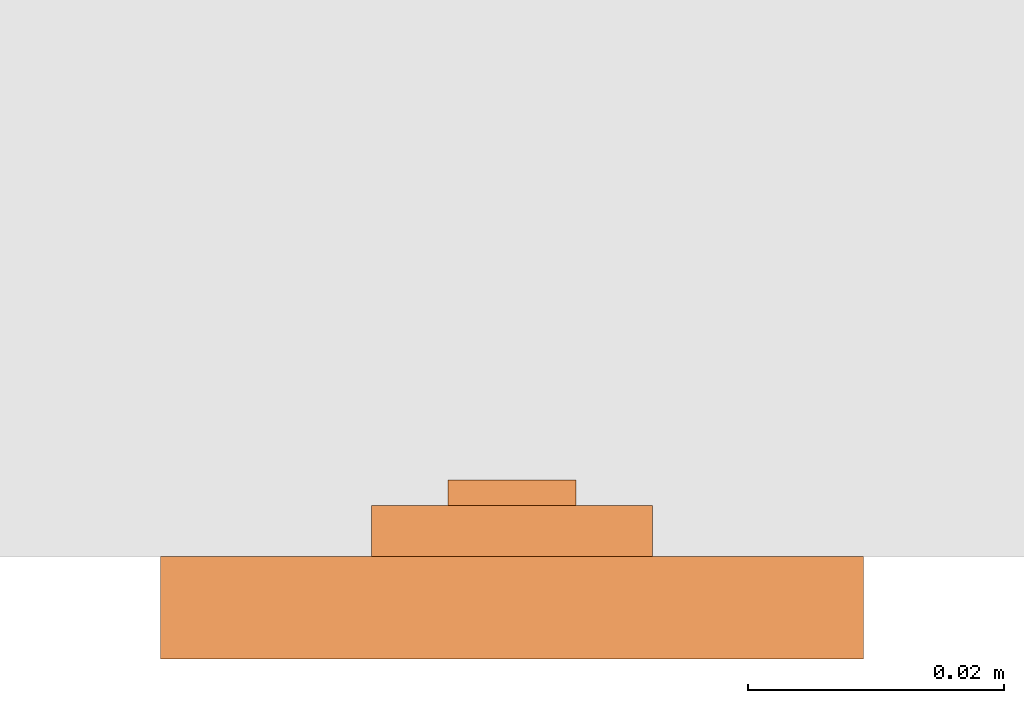
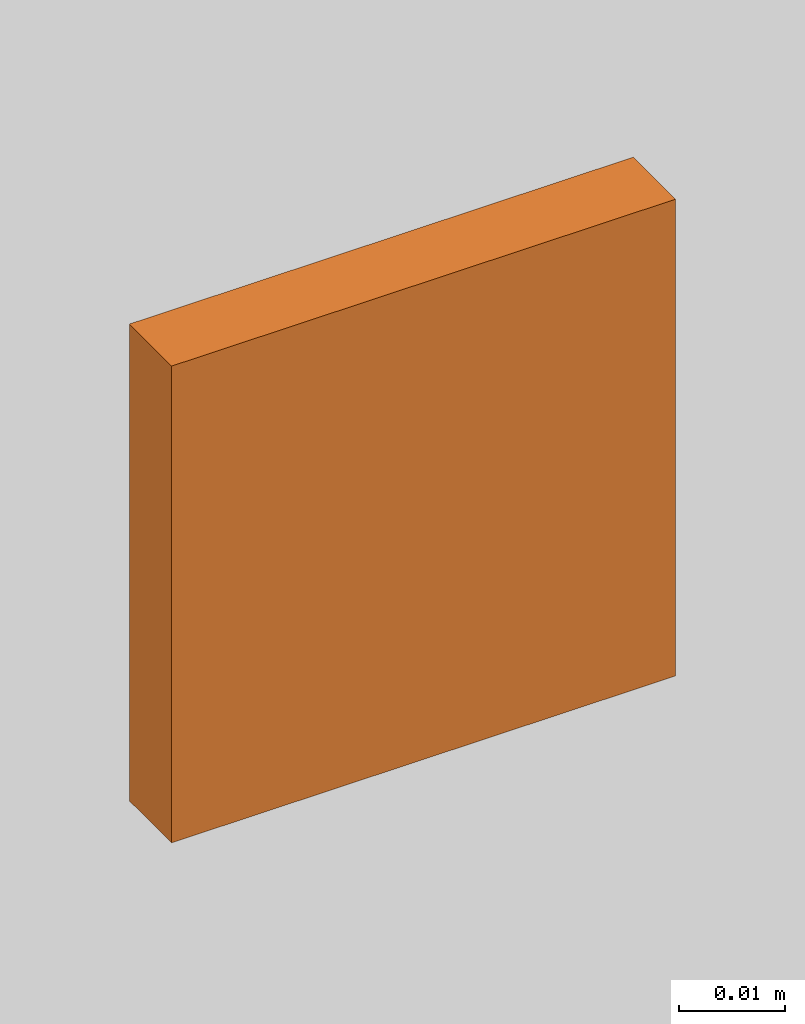
# One storey, part 2 of 2: 1 proxy.
"""IFC2X3 building model written with IfcOpenShell, lengths in millimetres."""

from ifc_helpers import new_model, entity, si_unit, converted_unit, derived_unit, direction, frame, origin, place, context, subcontext, project, spatial, faceted_brep, source, transform, mapped, material, type_object, type_shapes, element, save


model = new_model("IFC2X3")

# Units and contexts
model_context = context("Model", 3, precision=0.01, world=origin(), true_north=direction((6.12303176911189e-17, 1.0)))
body_context = subcontext(model_context, "Body", "Model", "MODEL_VIEW")
ifc_project = project(units=[si_unit("LENGTHUNIT", "METRE", prefix="MILLI"), si_unit("AREAUNIT", "SQUARE_METRE"), si_unit("VOLUMEUNIT", "CUBIC_METRE"), converted_unit("PLANEANGLEUNIT", "DEGREE", entity("IfcRatioMeasure", 0.0174532925199433), si_unit("PLANEANGLEUNIT", "RADIAN"), dimensions=[0, 0, 0, 0, 0, 0, 0]), si_unit("MASSUNIT", "GRAM", prefix="KILO"), si_unit("TIMEUNIT", "SECOND"), si_unit("FREQUENCYUNIT", "HERTZ"), si_unit("THERMODYNAMICTEMPERATUREUNIT", "DEGREE_CELSIUS"), derived_unit("THERMALTRANSMITTANCEUNIT", [(si_unit("MASSUNIT", "GRAM", prefix="KILO"), 1), (si_unit("THERMODYNAMICTEMPERATUREUNIT", "KELVIN"), -1), (si_unit("TIMEUNIT", "SECOND"), -3)]), derived_unit("VOLUMETRICFLOWRATEUNIT", [(si_unit("LENGTHUNIT", "METRE"), 3), (si_unit("TIMEUNIT", "SECOND"), -1)]), si_unit("ELECTRICCURRENTUNIT", "AMPERE"), si_unit("ELECTRICVOLTAGEUNIT", "VOLT"), si_unit("POWERUNIT", "WATT"), si_unit("FORCEUNIT", "NEWTON", prefix="KILO"), si_unit("ILLUMINANCEUNIT", "LUX"), si_unit("LUMINOUSFLUXUNIT", "LUMEN"), si_unit("LUMINOUSINTENSITYUNIT", "CANDELA"), derived_unit("USERDEFINED", [(si_unit("MASSUNIT", "GRAM", prefix="KILO"), -1), (si_unit("LENGTHUNIT", "METRE"), -2), (si_unit("TIMEUNIT", "SECOND"), 3), (si_unit("LUMINOUSFLUXUNIT", "LUMEN"), 1)]), derived_unit("LINEARVELOCITYUNIT", [(si_unit("LENGTHUNIT", "METRE"), 1), (si_unit("TIMEUNIT", "SECOND"), -1)]), si_unit("PRESSUREUNIT", "PASCAL"), derived_unit("USERDEFINED", [(si_unit("LENGTHUNIT", "METRE"), -2), (si_unit("MASSUNIT", "GRAM", prefix="KILO"), 1), (si_unit("TIMEUNIT", "SECOND"), -2)])], contexts=[model_context])

# Site, building, storey
site_placement = place(None, origin())
site = spatial("IfcSite", under=ifc_project, at=site_placement, CompositionType="ELEMENT")
building_placement = place(site_placement, origin())
building = spatial("IfcBuilding", under=site, at=building_placement, CompositionType="ELEMENT")
storey_placement = place(building_placement, origin())
storey = spatial("IfcBuildingStorey", under=building, at=storey_placement, Name="Ebene 1", CompositionType="ELEMENT", Elevation=0.0)

# Proxy
ifc_material = material()
building_element_proxy_type = type_object("IfcBuildingElementProxyType", Name="213326", PredefinedType="NOTDEFINED", material=ifc_material)
shared_shape = source(origin(), body_context, "Body", "Brep", [
    faceted_brep([(-5.0, -9.34665715646335, 6.0), (-2.57734690540104, -10.2818910191482, 6.0), (0.0, -10.6000000000252, 6.0), (2.57734690543849, -10.2818910191482, 6.0), (5.0, -9.34665715646362, 6.0), (5.0, 9.34665715641327, 6.0), (2.57734690543855, 10.2818910190978, 6.0), (0.0, 10.5999999999749, 6.0), (-2.57734690540097, 10.2818910190978, 6.0), (-5.0, 9.34665715641327, 6.0), (-2.57734690540097, 10.2818910190978, -6.0), (0.0, 10.5999999999749, -6.0), (2.57734690543855, 10.2818910190978, -6.0), (5.0, 9.34665715641327, -6.0), (5.0, -9.34665715646362, -6.0), (2.57734690543849, -10.2818910191482, -6.0), (0.0, -10.6000000000252, -6.0), (-2.57734690540104, -10.2818910191482, -6.0), (-5.0, -9.34665715646362, -6.0), (-5.0, 9.34665715641327, -6.0)], [[[0, 1, 2, 3, 4, 5, 6, 7, 8, 9]], [[10, 11, 12, 13, 14, 15, 16, 17, 18, 19]], [[5, 4, 14, 13]], [[13, 12, 6, 5]], [[6, 12, 11, 7]], [[11, 10, 8, 7]], [[10, 19, 9, 8]], [[0, 9, 19, 18]], [[18, 17, 1, 0]], [[1, 17, 16, 2]], [[16, 15, 3, 2]], [[15, 14, 4, 3]]]),
    faceted_brep([(-11.0, 17.4999999999746, 6.0), (-11.0, 16.4999999999746, 6.0), (11.0, 16.4999999999747, 6.0), (11.0, 17.4999999999747, 6.0), (-11.0, 17.4999999999746, -4.0), (-11.0, 16.4999999999746, -4.0), (11.0, 16.4999999999747, -4.0), (11.0, 17.4999999999747, -4.0)], [[[0, 1, 2, 3]], [[1, 0, 4, 5]], [[2, 1, 5, 6]], [[3, 2, 6, 7]], [[0, 3, 7, 4]], [[4, 7, 6, 5]]]),
    faceted_brep([(11.0, -16.5000000000253, -4.0), (11.0, -17.5000000000253, -4.0), (-11.0, -17.5000000000253, -4.0), (-11.0, -16.5000000000253, -4.0), (-11.0, -16.5000000000253, 6.0), (11.0, -16.5000000000253, 6.0), (-11.0, -17.5000000000253, 6.0), (11.0, -17.5000000000253, 6.0)], [[[0, 1, 2, 3]], [[4, 5, 0, 3]], [[6, 4, 3, 2]], [[7, 6, 2, 1]], [[5, 7, 1, 0]], [[5, 4, 6, 7]]]),
    faceted_brep([(27.5000000000187, 27.4999999999747, 8.0), (-27.4999999999813, 27.4999999999747, 8.0), (-27.4999999999813, -27.5000000000253, 8.0), (27.5000000000187, -27.5000000000253, 8.0), (27.5000000000187, 27.4999999999747, 0.0), (27.5000000000187, -27.5000000000253, 0.0), (-27.4999999999813, -27.5000000000253, 0.0), (-27.4999999999813, 27.4999999999747, 0.0), (26.0, -26.0, 0.0), (26.0, 26.0, 0.0), (-26.0, 26.0, 0.0), (-26.0, -26.0, 0.0), (26.0, -26.0, 6.0), (-26.0, -26.0, 6.0), (-26.0, 26.0, 6.0), (26.0, 26.0, 6.0)], [[[0, 1, 2, 3]], [[4, 5, 6, 7], [8, 9, 10, 11]], [[1, 0, 4, 7]], [[2, 1, 7, 6]], [[3, 2, 6, 5]], [[0, 3, 5, 4]], [[12, 13, 14, 15]], [[12, 15, 9, 8]], [[15, 14, 10, 9]], [[14, 13, 11, 10]], [[13, 12, 8, 11]]]),
])
type_shapes(building_element_proxy_type, [shared_shape])
proxy_placement = place(storey_placement, frame((-5348.20805814269, 1080.2630189541, 257.17174534746), z_axis=(0.0, -1.0, 0.0), x_axis=(1.0, 0.0, 0.0)))
element("IfcBuildingElementProxy", 1, at=proxy_placement, inside=storey, type_object=building_element_proxy_type, material=ifc_material, ObjectType="213326", context=body_context, shape_type="MappedRepresentation", body=[
    mapped(shared_shape, transform((0.0, 0.0, 0.0), scale=1.0)),
])

save(model, "model.ifc")
